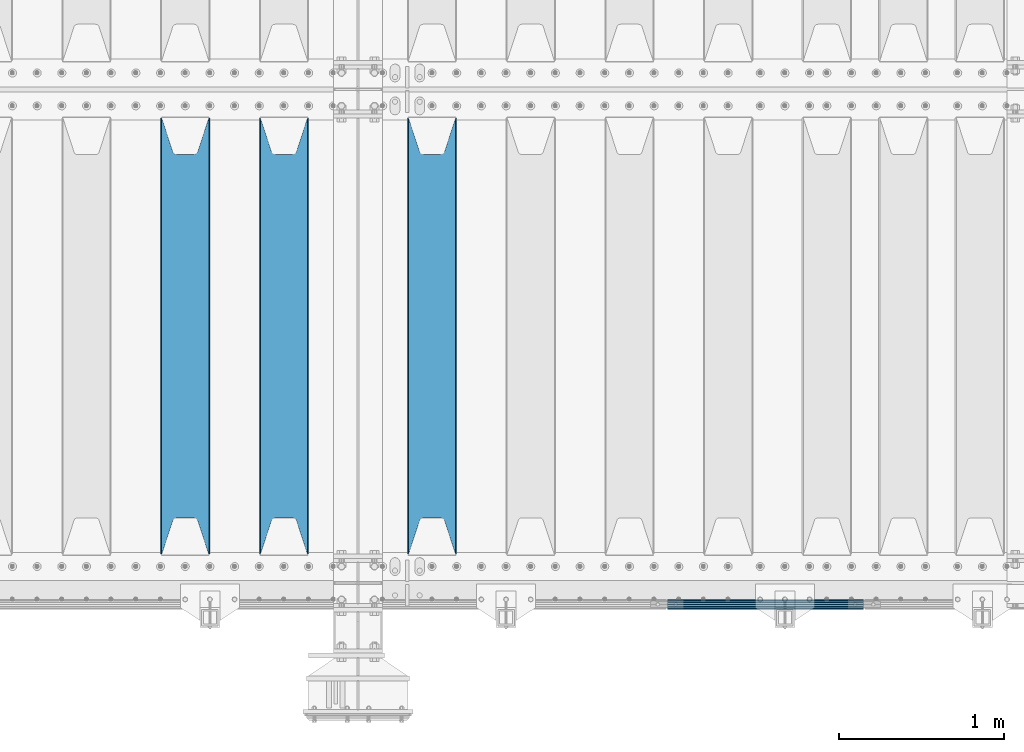
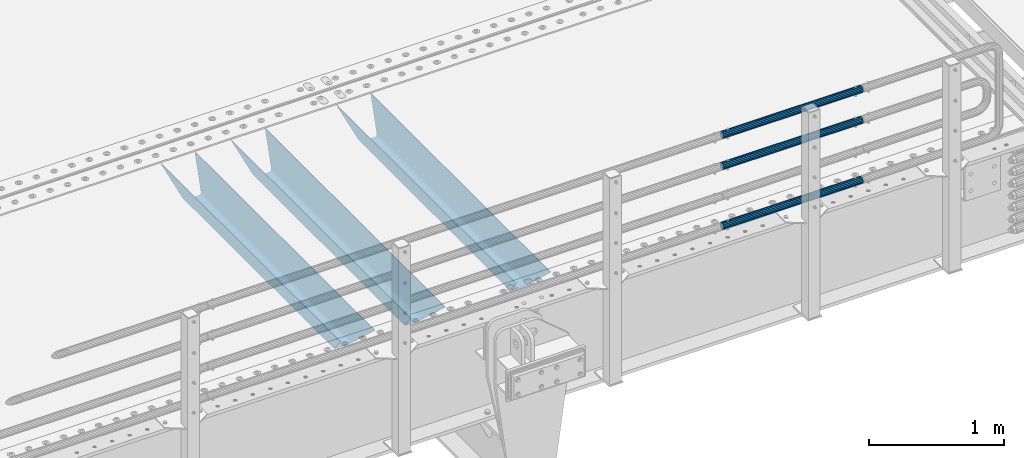
# One storey, part 115 of 247: 6 beams.
"""IFC2X3 building model written with IfcOpenShell, lengths in millimetres."""

from ifc_helpers import new_model, si_unit, frame, origin_with_axes, place, context, subcontext, project, spatial, faceted_brep, material, type_object, element, save


model = new_model("IFC2X3")

# Units and contexts
model_context = context("Model", 3, precision=1e-05, world=origin_with_axes())
body_context = subcontext(model_context, "Body", "Model", "MODEL_VIEW")
ifc_project = project(units=[si_unit("LENGTHUNIT", "METRE", prefix="MILLI"), si_unit("AREAUNIT", "SQUARE_METRE"), si_unit("VOLUMEUNIT", "CUBIC_METRE"), si_unit("MASSUNIT", "GRAM", prefix="KILO"), si_unit("TIMEUNIT", "SECOND"), si_unit("PLANEANGLEUNIT", "RADIAN"), si_unit("SOLIDANGLEUNIT", "STERADIAN"), si_unit("THERMODYNAMICTEMPERATUREUNIT", "DEGREE_CELSIUS"), si_unit("LUMINOUSINTENSITYUNIT", "LUMEN")], contexts=[model_context])

# Site, building, storey
site_placement = place(None, origin_with_axes())
site = spatial("IfcSite", under=ifc_project, at=site_placement, CompositionType="ELEMENT")
building_placement = place(site_placement, origin_with_axes())
building = spatial("IfcBuilding", under=site, at=building_placement, Name="Standard", CompositionType="ELEMENT")
storey_placement = place(building_placement, origin_with_axes())
storey = spatial("IfcBuildingStorey", under=building, at=storey_placement, Name="Undefined", CompositionType="ELEMENT", Elevation=0.0)

# Beams
ifc_material_1 = material(Name="STEEL/S355N")
beam_type_1 = type_object("IfcBeamType", PredefinedType="NOTDEFINED")
beam_1_placement = place(storey_placement, frame((12700.0, 175.0, -115.0), z_axis=(0.0, 0.0, 1.0), x_axis=(0.0, 1.0, 0.0)))
element("IfcBeam", 1, at=beam_1_placement, inside=storey, type_object=beam_type_1, material=ifc_material_1, context=body_context, shape_type="Brep", body=[
    faceted_brep([(0.0, 150.0, 115.0), (0.0, 143.689999999999, 115.0), (2650.00000000297, 143.689999999999, 115.0), (2650.00000000297, 150.0, 115.0), (2650.00000000297, 142.059565218402, 110.0000000031), (2650.00000000297, 148.369565218403, 110.0000000031), (2441.90079219208, -80.1103600731112, -98.0992078077845), (2437.7588105432, -77.5672621345584, -102.241189456673), (2434.06523489746, -74.4080125315522, -105.934765102404), (2430.91086095089, -70.710272125576, -109.089139048974), (2428.37322971128, -66.5649389910068, -111.626770288588), (2426.51472138054, -62.0739139532889, -113.485278619323), (2425.38102192091, -57.3475956567672, -114.618978078955), (2424.99999999987, -52.5021667386536, -115.0), (2424.99999999987, 52.5021667386536, -115.0), (2425.38102192091, 57.3475956567672, -114.618978078955), (2426.51472138054, 62.0739139532889, -113.485278619323), (2428.37322971128, 66.5649389910068, -111.626770288588), (2430.91086095089, 70.710272125576, -109.089139048974), (2434.06523489746, 74.4080125315522, -105.934765102404), (2437.7588105432, 77.5672621345584, -102.241189456673), (2441.90079219208, 80.1103600731112, -98.0992078077846), (2446.38936140511, 81.9747917625791, -93.6106385947584), (2448.24948500409, 76.2713538057251, -91.7505149957729), (2444.62967112262, 74.76777986261, -95.3703288772456), (2441.28936334126, 72.7168944282894, -98.710636658607), (2438.31067330438, 70.1691124903846, -101.689326695487), (2435.76682334747, 67.1870637758839, -104.233176652398), (2433.72034654133, 63.8440531834895, -106.279653458539), (2432.22154950041, 60.222258798236, -107.778450499454), (2431.30727574265, 56.4107117849089, -108.692724257221), (2430.99999999987, 52.5031078186876, -109.0), (2430.99999999987, -52.5031078186876, -109.0), (2431.30727574265, -56.4107117849089, -108.692724257221), (2432.22154950041, -60.222258798236, -107.778450499454), (2433.72034654133, -63.8440531834895, -106.279653458539), (2435.76682334747, -67.1870637758839, -104.233176652398), (2438.31067330438, -70.1691124903846, -101.689326695487), (2441.28936334126, -72.7168944282894, -98.7106366586071), (2444.62967112262, -74.76777986261, -95.3703288772457), (2448.24948500409, -76.2713538057251, -91.7505149957729), (2650.00000000297, -142.059565218402, 110.0000000031), (2650.00000000297, -148.369565218403, 110.0000000031), (2446.38936140511, -81.9747917625791, -93.6106385947584), (2650.00000000297, -143.689999999999, 115.0), (2650.00000000297, -150.0, 115.0), (0.0, -143.689999999999, 115.0), (0.0, -150.0, 115.0), (0.0, -148.369565218261, 110.000000002663), (203.610638597422, -81.9747917625791, -93.6106385947584), (208.099207810448, -80.1103600731112, -98.0992078077845), (212.241189459336, -77.5672621345584, -102.241189456673), (215.934765105068, -74.4080125315522, -105.934765102404), (219.089139051637, -70.710272125576, -109.089139048974), (221.626770291251, -66.5649389910068, -111.626770288588), (223.485278621985, -62.0739139532889, -113.485278619323), (224.618978081617, -57.3475956567672, -114.618978078955), (225.000000002663, -52.5021667386536, -115.0), (225.000000002663, 52.5021667386536, -115.0), (224.618978081617, 57.3475956567672, -114.618978078955), (223.485278621985, 62.0739139532889, -113.485278619323), (221.626770291251, 66.5649389910068, -111.626770288588), (219.089139051637, 70.710272125576, -109.089139048974), (215.934765105068, 74.4080125315522, -105.934765102404), (212.241189459336, 77.5672621345584, -102.241189456673), (208.099207810448, 80.1103600731112, -98.0992078077846), (203.610638597422, 81.9747917625791, -93.6106385947584), (0.0, 148.369565218261, 110.000000002663), (0.0, 142.05956521826, 110.000000002663), (201.750514998436, 76.2713538057251, -91.7505149957729), (205.370328879908, 74.76777986261, -95.3703288772456), (208.710636661271, 72.7168944282894, -98.710636658607), (211.68932669815, 70.1691124903846, -101.689326695487), (214.233176655061, 67.1870637758839, -104.233176652398), (216.279653461202, 63.8440531834895, -106.279653458539), (217.778450502117, 60.222258798236, -107.778450499454), (218.692724259885, 56.4107117849089, -108.692724257221), (219.000000002663, 52.5031078186876, -109.0), (219.000000002663, -52.5031078186876, -109.0), (218.692724259885, -56.4107117849089, -108.692724257221), (217.778450502117, -60.222258798236, -107.778450499454), (216.279653461202, -63.8440531834895, -106.279653458539), (214.233176655061, -67.1870637758839, -104.233176652398), (211.68932669815, -70.1691124903846, -101.689326695487), (208.710636661271, -72.7168944282894, -98.7106366586071), (205.370328879908, -74.76777986261, -95.3703288772457), (201.750514998436, -76.2713538057251, -91.7505149957729), (0.0, -142.05956521826, 110.000000002663)], [[[0, 1, 2, 3]], [[3, 2, 4, 5]], [[6, 7, 8, 9, 10, 11, 12, 13, 14, 15, 16, 17, 18, 19, 20, 21, 22, 5, 4, 23, 24, 25, 26, 27, 28, 29, 30, 31, 32, 33, 34, 35, 36, 37, 38, 39, 40, 41, 42, 43]], [[44, 45, 42, 41]], [[46, 47, 45, 44]], [[43, 42, 45, 47, 48, 49]], [[6, 43, 49, 50]], [[7, 6, 50, 51]], [[8, 7, 51, 52]], [[9, 8, 52, 53]], [[10, 9, 53, 54]], [[11, 10, 54, 55]], [[12, 11, 55, 56]], [[13, 12, 56, 57]], [[14, 13, 57, 58]], [[15, 14, 58, 59]], [[16, 15, 59, 60]], [[17, 16, 60, 61]], [[18, 17, 61, 62]], [[19, 18, 62, 63]], [[20, 19, 63, 64]], [[21, 20, 64, 65]], [[22, 21, 65, 66]], [[0, 3, 5, 22, 66, 67]], [[1, 0, 67, 68]], [[23, 4, 2, 1, 68, 69]], [[24, 23, 69, 70]], [[25, 24, 70, 71]], [[26, 25, 71, 72]], [[27, 26, 72, 73]], [[28, 27, 73, 74]], [[29, 28, 74, 75]], [[30, 29, 75, 76]], [[31, 30, 76, 77]], [[32, 31, 77, 78]], [[33, 32, 78, 79]], [[34, 33, 79, 80]], [[35, 34, 80, 81]], [[36, 35, 81, 82]], [[37, 36, 82, 83]], [[38, 37, 83, 84]], [[39, 38, 84, 85]], [[40, 39, 85, 86]], [[46, 44, 41, 40, 86, 87]], [[47, 46, 87, 48]], [[86, 85, 84, 83, 82, 81, 80, 79, 78, 77, 76, 75, 74, 73, 72, 71, 70, 69, 68, 67, 66, 65, 64, 63, 62, 61, 60, 59, 58, 57, 56, 55, 54, 53, 52, 51, 50, 49, 48, 87]]]),
])
beam_2_placement = place(storey_placement, frame((11800.0, 175.0, -115.0), z_axis=(0.0, 0.0, 1.0), x_axis=(0.0, 1.0, 0.0)))
element("IfcBeam", 2, at=beam_2_placement, inside=storey, type_object=beam_type_1, material=ifc_material_1, context=body_context, shape_type="Brep", body=[
    faceted_brep([(0.0, 150.0, 115.0), (0.0, 143.689999999999, 115.0), (2650.00000000297, 143.689999999999, 115.0), (2650.00000000297, 150.0, 115.0), (2650.00000000297, 142.059565218402, 110.0000000031), (2650.00000000297, 148.369565218403, 110.0000000031), (2441.90079219208, -80.1103600731112, -98.0992078077845), (2437.7588105432, -77.5672621345584, -102.241189456673), (2434.06523489746, -74.4080125315522, -105.934765102404), (2430.91086095089, -70.710272125576, -109.089139048974), (2428.37322971128, -66.5649389910068, -111.626770288588), (2426.51472138054, -62.0739139532889, -113.485278619323), (2425.38102192091, -57.3475956567672, -114.618978078955), (2424.99999999987, -52.5021667386536, -115.0), (2424.99999999987, 52.5021667386536, -115.0), (2425.38102192091, 57.3475956567672, -114.618978078955), (2426.51472138054, 62.0739139532889, -113.485278619323), (2428.37322971128, 66.5649389910068, -111.626770288588), (2430.91086095089, 70.710272125576, -109.089139048974), (2434.06523489746, 74.4080125315522, -105.934765102404), (2437.7588105432, 77.5672621345584, -102.241189456673), (2441.90079219208, 80.1103600731112, -98.0992078077846), (2446.38936140511, 81.9747917625791, -93.6106385947584), (2448.24948500409, 76.2713538057251, -91.7505149957729), (2444.62967112262, 74.76777986261, -95.3703288772456), (2441.28936334126, 72.7168944282894, -98.710636658607), (2438.31067330438, 70.1691124903846, -101.689326695487), (2435.76682334747, 67.1870637758839, -104.233176652398), (2433.72034654133, 63.8440531834895, -106.279653458539), (2432.22154950041, 60.222258798236, -107.778450499454), (2431.30727574265, 56.4107117849089, -108.692724257221), (2430.99999999987, 52.5031078186876, -109.0), (2430.99999999987, -52.5031078186876, -109.0), (2431.30727574265, -56.4107117849089, -108.692724257221), (2432.22154950041, -60.222258798236, -107.778450499454), (2433.72034654133, -63.8440531834895, -106.279653458539), (2435.76682334747, -67.1870637758839, -104.233176652398), (2438.31067330438, -70.1691124903846, -101.689326695487), (2441.28936334126, -72.7168944282894, -98.7106366586071), (2444.62967112262, -74.76777986261, -95.3703288772457), (2448.24948500409, -76.2713538057251, -91.7505149957729), (2650.00000000297, -142.059565218402, 110.0000000031), (2650.00000000297, -148.369565218403, 110.0000000031), (2446.38936140511, -81.9747917625791, -93.6106385947584), (2650.00000000297, -143.689999999999, 115.0), (2650.00000000297, -150.0, 115.0), (0.0, -143.689999999999, 115.0), (0.0, -150.0, 115.0), (0.0, -148.369565218261, 110.000000002663), (203.610638597422, -81.9747917625791, -93.6106385947584), (208.099207810448, -80.1103600731112, -98.0992078077845), (212.241189459336, -77.5672621345584, -102.241189456673), (215.934765105068, -74.4080125315522, -105.934765102404), (219.089139051637, -70.710272125576, -109.089139048974), (221.626770291251, -66.5649389910068, -111.626770288588), (223.485278621985, -62.0739139532889, -113.485278619323), (224.618978081617, -57.3475956567672, -114.618978078955), (225.000000002663, -52.5021667386536, -115.0), (225.000000002663, 52.5021667386536, -115.0), (224.618978081617, 57.3475956567672, -114.618978078955), (223.485278621985, 62.0739139532889, -113.485278619323), (221.626770291251, 66.5649389910068, -111.626770288588), (219.089139051637, 70.710272125576, -109.089139048974), (215.934765105068, 74.4080125315522, -105.934765102404), (212.241189459336, 77.5672621345584, -102.241189456673), (208.099207810448, 80.1103600731112, -98.0992078077846), (203.610638597422, 81.9747917625791, -93.6106385947584), (0.0, 148.369565218261, 110.000000002663), (0.0, 142.05956521826, 110.000000002663), (201.750514998436, 76.2713538057251, -91.7505149957729), (205.370328879908, 74.76777986261, -95.3703288772456), (208.710636661271, 72.7168944282894, -98.710636658607), (211.68932669815, 70.1691124903846, -101.689326695487), (214.233176655061, 67.1870637758839, -104.233176652398), (216.279653461202, 63.8440531834895, -106.279653458539), (217.778450502117, 60.222258798236, -107.778450499454), (218.692724259885, 56.4107117849089, -108.692724257221), (219.000000002663, 52.5031078186876, -109.0), (219.000000002663, -52.5031078186876, -109.0), (218.692724259885, -56.4107117849089, -108.692724257221), (217.778450502117, -60.222258798236, -107.778450499454), (216.279653461202, -63.8440531834895, -106.279653458539), (214.233176655061, -67.1870637758839, -104.233176652398), (211.68932669815, -70.1691124903846, -101.689326695487), (208.710636661271, -72.7168944282894, -98.7106366586071), (205.370328879908, -74.76777986261, -95.3703288772457), (201.750514998436, -76.2713538057251, -91.7505149957729), (0.0, -142.05956521826, 110.000000002663)], [[[0, 1, 2, 3]], [[3, 2, 4, 5]], [[6, 7, 8, 9, 10, 11, 12, 13, 14, 15, 16, 17, 18, 19, 20, 21, 22, 5, 4, 23, 24, 25, 26, 27, 28, 29, 30, 31, 32, 33, 34, 35, 36, 37, 38, 39, 40, 41, 42, 43]], [[44, 45, 42, 41]], [[46, 47, 45, 44]], [[43, 42, 45, 47, 48, 49]], [[6, 43, 49, 50]], [[7, 6, 50, 51]], [[8, 7, 51, 52]], [[9, 8, 52, 53]], [[10, 9, 53, 54]], [[11, 10, 54, 55]], [[12, 11, 55, 56]], [[13, 12, 56, 57]], [[14, 13, 57, 58]], [[15, 14, 58, 59]], [[16, 15, 59, 60]], [[17, 16, 60, 61]], [[18, 17, 61, 62]], [[19, 18, 62, 63]], [[20, 19, 63, 64]], [[21, 20, 64, 65]], [[22, 21, 65, 66]], [[0, 3, 5, 22, 66, 67]], [[1, 0, 67, 68]], [[23, 4, 2, 1, 68, 69]], [[24, 23, 69, 70]], [[25, 24, 70, 71]], [[26, 25, 71, 72]], [[27, 26, 72, 73]], [[28, 27, 73, 74]], [[29, 28, 74, 75]], [[30, 29, 75, 76]], [[31, 30, 76, 77]], [[32, 31, 77, 78]], [[33, 32, 78, 79]], [[34, 33, 79, 80]], [[35, 34, 80, 81]], [[36, 35, 81, 82]], [[37, 36, 82, 83]], [[38, 37, 83, 84]], [[39, 38, 84, 85]], [[40, 39, 85, 86]], [[46, 44, 41, 40, 86, 87]], [[47, 46, 87, 48]], [[86, 85, 84, 83, 82, 81, 80, 79, 78, 77, 76, 75, 74, 73, 72, 71, 70, 69, 68, 67, 66, 65, 64, 63, 62, 61, 60, 59, 58, 57, 56, 55, 54, 53, 52, 51, 50, 49, 48, 87]]]),
])
beam_3_placement = place(storey_placement, frame((11200.0, 175.0, -115.0), z_axis=(0.0, 0.0, 1.0), x_axis=(0.0, 1.0, 0.0)))
element("IfcBeam", 3, at=beam_3_placement, inside=storey, type_object=beam_type_1, material=ifc_material_1, context=body_context, shape_type="Brep", body=[
    faceted_brep([(0.0, 150.0, 115.0), (0.0, 143.689999999999, 115.0), (2650.00000000297, 143.689999999999, 115.0), (2650.00000000297, 150.0, 115.0), (2650.00000000297, 142.059565218402, 110.0000000031), (2650.00000000297, 148.369565218403, 110.0000000031), (2441.90079219208, -80.1103600731112, -98.0992078077845), (2437.7588105432, -77.5672621345584, -102.241189456673), (2434.06523489746, -74.4080125315522, -105.934765102404), (2430.91086095089, -70.710272125576, -109.089139048974), (2428.37322971128, -66.5649389910068, -111.626770288588), (2426.51472138054, -62.0739139532889, -113.485278619323), (2425.38102192091, -57.3475956567672, -114.618978078955), (2424.99999999987, -52.5021667386536, -115.0), (2424.99999999987, 52.5021667386536, -115.0), (2425.38102192091, 57.3475956567672, -114.618978078955), (2426.51472138054, 62.0739139532889, -113.485278619323), (2428.37322971128, 66.5649389910068, -111.626770288588), (2430.91086095089, 70.710272125576, -109.089139048974), (2434.06523489746, 74.4080125315522, -105.934765102404), (2437.7588105432, 77.5672621345584, -102.241189456673), (2441.90079219208, 80.1103600731112, -98.0992078077846), (2446.38936140511, 81.9747917625791, -93.6106385947584), (2448.24948500409, 76.2713538057251, -91.7505149957729), (2444.62967112262, 74.76777986261, -95.3703288772456), (2441.28936334126, 72.7168944282894, -98.710636658607), (2438.31067330438, 70.1691124903846, -101.689326695487), (2435.76682334747, 67.1870637758839, -104.233176652398), (2433.72034654133, 63.8440531834895, -106.279653458539), (2432.22154950041, 60.222258798236, -107.778450499454), (2431.30727574265, 56.4107117849089, -108.692724257221), (2430.99999999987, 52.5031078186876, -109.0), (2430.99999999987, -52.5031078186876, -109.0), (2431.30727574265, -56.4107117849089, -108.692724257221), (2432.22154950041, -60.222258798236, -107.778450499454), (2433.72034654133, -63.8440531834895, -106.279653458539), (2435.76682334747, -67.1870637758839, -104.233176652398), (2438.31067330438, -70.1691124903846, -101.689326695487), (2441.28936334126, -72.7168944282894, -98.7106366586071), (2444.62967112262, -74.76777986261, -95.3703288772457), (2448.24948500409, -76.2713538057251, -91.7505149957729), (2650.00000000297, -142.059565218402, 110.0000000031), (2650.00000000297, -148.369565218403, 110.0000000031), (2446.38936140511, -81.9747917625791, -93.6106385947584), (2650.00000000297, -143.689999999999, 115.0), (2650.00000000297, -150.0, 115.0), (0.0, -143.689999999999, 115.0), (0.0, -150.0, 115.0), (0.0, -148.369565218261, 110.000000002663), (203.610638597422, -81.9747917625791, -93.6106385947584), (208.099207810448, -80.1103600731112, -98.0992078077845), (212.241189459336, -77.5672621345584, -102.241189456673), (215.934765105068, -74.4080125315522, -105.934765102404), (219.089139051637, -70.710272125576, -109.089139048974), (221.626770291251, -66.5649389910068, -111.626770288588), (223.485278621985, -62.0739139532889, -113.485278619323), (224.618978081617, -57.3475956567672, -114.618978078955), (225.000000002663, -52.5021667386536, -115.0), (225.000000002663, 52.5021667386536, -115.0), (224.618978081617, 57.3475956567672, -114.618978078955), (223.485278621985, 62.0739139532889, -113.485278619323), (221.626770291251, 66.5649389910068, -111.626770288588), (219.089139051637, 70.710272125576, -109.089139048974), (215.934765105068, 74.4080125315522, -105.934765102404), (212.241189459336, 77.5672621345584, -102.241189456673), (208.099207810448, 80.1103600731112, -98.0992078077846), (203.610638597422, 81.9747917625791, -93.6106385947584), (0.0, 148.369565218261, 110.000000002663), (0.0, 142.05956521826, 110.000000002663), (201.750514998436, 76.2713538057251, -91.7505149957729), (205.370328879908, 74.76777986261, -95.3703288772456), (208.710636661271, 72.7168944282894, -98.710636658607), (211.68932669815, 70.1691124903846, -101.689326695487), (214.233176655061, 67.1870637758839, -104.233176652398), (216.279653461202, 63.8440531834895, -106.279653458539), (217.778450502117, 60.222258798236, -107.778450499454), (218.692724259885, 56.4107117849089, -108.692724257221), (219.000000002663, 52.5031078186876, -109.0), (219.000000002663, -52.5031078186876, -109.0), (218.692724259885, -56.4107117849089, -108.692724257221), (217.778450502117, -60.222258798236, -107.778450499454), (216.279653461202, -63.8440531834895, -106.279653458539), (214.233176655061, -67.1870637758839, -104.233176652398), (211.68932669815, -70.1691124903846, -101.689326695487), (208.710636661271, -72.7168944282894, -98.7106366586071), (205.370328879908, -74.76777986261, -95.3703288772457), (201.750514998436, -76.2713538057251, -91.7505149957729), (0.0, -142.05956521826, 110.000000002663)], [[[0, 1, 2, 3]], [[3, 2, 4, 5]], [[6, 7, 8, 9, 10, 11, 12, 13, 14, 15, 16, 17, 18, 19, 20, 21, 22, 5, 4, 23, 24, 25, 26, 27, 28, 29, 30, 31, 32, 33, 34, 35, 36, 37, 38, 39, 40, 41, 42, 43]], [[44, 45, 42, 41]], [[46, 47, 45, 44]], [[43, 42, 45, 47, 48, 49]], [[6, 43, 49, 50]], [[7, 6, 50, 51]], [[8, 7, 51, 52]], [[9, 8, 52, 53]], [[10, 9, 53, 54]], [[11, 10, 54, 55]], [[12, 11, 55, 56]], [[13, 12, 56, 57]], [[14, 13, 57, 58]], [[15, 14, 58, 59]], [[16, 15, 59, 60]], [[17, 16, 60, 61]], [[18, 17, 61, 62]], [[19, 18, 62, 63]], [[20, 19, 63, 64]], [[21, 20, 64, 65]], [[22, 21, 65, 66]], [[0, 3, 5, 22, 66, 67]], [[1, 0, 67, 68]], [[23, 4, 2, 1, 68, 69]], [[24, 23, 69, 70]], [[25, 24, 70, 71]], [[26, 25, 71, 72]], [[27, 26, 72, 73]], [[28, 27, 73, 74]], [[29, 28, 74, 75]], [[30, 29, 75, 76]], [[31, 30, 76, 77]], [[32, 31, 77, 78]], [[33, 32, 78, 79]], [[34, 33, 79, 80]], [[35, 34, 80, 81]], [[36, 35, 81, 82]], [[37, 36, 82, 83]], [[38, 37, 83, 84]], [[39, 38, 84, 85]], [[40, 39, 85, 86]], [[46, 44, 41, 40, 86, 87]], [[47, 46, 87, 48]], [[86, 85, 84, 83, 82, 81, 80, 79, 78, 77, 76, 75, 74, 73, 72, 71, 70, 69, 68, 67, 66, 65, 64, 63, 62, 61, 60, 59, 58, 57, 56, 55, 54, 53, 52, 51, 50, 49, 48, 87]]]),
])
ifc_material_2 = material()
beam_type_2 = type_object("IfcBeamType", PredefinedType="NOTDEFINED")
beam_4_placement = place(storey_placement, frame((14132.0000000001, -129.850000000402, 149.549999999726), z_axis=(0.0, -0.999999999999548, -9.5100000000016e-07), x_axis=(1.0, 0.0, 0.0)))
element("IfcBeam", 4, at=beam_4_placement, inside=storey, type_object=beam_type_2, material=ifc_material_2, context=body_context, shape_type="Brep", body=[
    faceted_brep([(0.0, -26.5499999999993, 0.0), (0.0, -24.5290015881747, 10.1602451292931), (1190.0, -24.5290015881747, 10.1602451292929), (1190.0, -26.55, 0.0), (0.0, -18.7736850405036, 18.7736850405028), (1190.0, -18.7736850405028, 18.7736850405036), (0.0, -10.1602451292929, 24.5290015881747), (1190.0, -10.1602451292931, 24.5290015881747), (0.0, 0.0, 26.55), (1190.0, 0.0, 26.5499999999993), (0.0, 10.1602451292929, 24.5290015881747), (1190.0, 10.1602451292932, 24.5290015881747), (0.0, 18.7736850405036, 18.7736850405028), (1190.0, 18.7736850405029, 18.7736850405036), (0.0, 24.5290015881747, 10.1602451292931), (1190.0, 24.5290015881747, 10.1602451292929), (0.0, 26.5499999999993, 0.0), (1190.0, 26.55, 0.0), (0.0, 24.5290015881747, -10.1602451292931), (1190.0, 24.5290015881747, -10.1602451292929), (0.0, 18.7736850405036, -18.7736850405028), (1190.0, 18.7736850405028, -18.7736850405036), (0.0, 10.1602451292929, -24.5290015881747), (1190.0, 10.1602451292931, -24.5290015881747), (0.0, 0.0, -26.55), (1190.0, 0.0, -26.5499999999993), (0.0, -10.1602451292929, -24.5290015881747), (1190.0, -10.1602451292931, -24.5290015881747), (0.0, -18.7736850405036, -18.7736850405028), (1190.0, -18.7736850405028, -18.7736850405036), (0.0, -24.5290015881747, -10.1602451292931), (1190.0, -24.5290015881747, -10.1602451292929), (0.0, -30.1499999999996, 0.0), (0.0, -27.8549679052148, -11.5379054858076), (1190.0, -27.8549679052153, -11.5379054858076), (1190.0, -30.15, 0.0), (0.0, -21.3192694527743, -21.3192694527752), (1190.0, -21.3192694527744, -21.3192694527752), (0.0, -11.5379054858076, -27.8549679052157), (1190.0, -11.5379054858075, -27.8549679052157), (0.0, 0.0, -30.1499999999996), (1190.0, 0.0, -30.1499999999996), (0.0, 11.5379054858076, -27.8549679052157), (1190.0, 11.5379054858075, -27.8549679052157), (0.0, 21.3192694527743, -21.3192694527752), (1190.0, 21.3192694527744, -21.3192694527752), (0.0, 27.8549679052157, -11.5379054858076), (1190.0, 27.8549679052153, -11.5379054858076), (0.0, 30.1499999999996, 0.0), (1190.0, 30.15, 0.0), (0.0, 27.8549679052157, 11.5379054858076), (1190.0, 27.8549679052153, 11.5379054858076), (0.0, 21.3192694527743, 21.3192694527752), (1190.0, 21.3192694527744, 21.3192694527752), (0.0, 11.5379054858076, 27.8549679052157), (1190.0, 11.5379054858075, 27.8549679052157), (0.0, 0.0, 30.1499999999996), (1190.0, 0.0, 30.1499999999996), (0.0, -11.5379054858076, 27.8549679052157), (1190.0, -11.5379054858075, 27.8549679052157), (0.0, -21.3192694527743, 21.3192694527752), (1190.0, -21.3192694527744, 21.3192694527752), (0.0, -27.8549679052157, 11.5379054858076), (1190.0, -27.8549679052153, 11.5379054858076)], [[[0, 1, 2, 3]], [[1, 4, 5, 2]], [[4, 6, 7, 5]], [[6, 8, 9, 7]], [[8, 10, 11, 9]], [[10, 12, 13, 11]], [[12, 14, 15, 13]], [[14, 16, 17, 15]], [[16, 18, 19, 17]], [[18, 20, 21, 19]], [[20, 22, 23, 21]], [[22, 24, 25, 23]], [[24, 26, 27, 25]], [[26, 28, 29, 27]], [[28, 30, 31, 29]], [[30, 0, 3, 31]], [[32, 33, 34, 35]], [[33, 36, 37, 34]], [[36, 38, 39, 37]], [[38, 40, 41, 39]], [[40, 42, 43, 41]], [[42, 44, 45, 43]], [[44, 46, 47, 45]], [[46, 48, 49, 47]], [[48, 50, 51, 49]], [[50, 52, 53, 51]], [[52, 54, 55, 53]], [[54, 56, 57, 55]], [[56, 58, 59, 57]], [[58, 60, 61, 59]], [[60, 62, 63, 61]], [[62, 32, 35, 63]], [[37, 39, 41, 43, 45, 47, 49, 51, 53, 55, 57, 59, 61, 63, 35, 34], [5, 7, 9, 11, 13, 15, 17, 19, 21, 23, 25, 27, 29, 31, 3, 2]], [[62, 60, 58, 56, 54, 52, 50, 48, 46, 44, 42, 40, 38, 36, 33, 32], [30, 28, 26, 24, 22, 20, 18, 16, 14, 12, 10, 8, 6, 4, 1, 0]]]),
])
beam_5_placement = place(storey_placement, frame((14132.0000000001, -129.850000000402, 969.549999999726), z_axis=(0.0, -0.999999999999548, -9.5100000000016e-07), x_axis=(1.0, 0.0, 0.0)))
element("IfcBeam", 5, at=beam_5_placement, inside=storey, type_object=beam_type_2, material=ifc_material_2, context=body_context, shape_type="Brep", body=[
    faceted_brep([(0.0, -26.5499999999993, 0.0), (0.0, -24.5290015881747, 10.1602451292931), (1190.0, -24.5290015881747, 10.1602451292929), (1190.0, -26.55, 0.0), (0.0, -18.7736850405036, 18.7736850405028), (1190.0, -18.7736850405028, 18.7736850405036), (0.0, -10.1602451292929, 24.5290015881747), (1190.0, -10.1602451292931, 24.5290015881747), (0.0, 0.0, 26.55), (1190.0, 0.0, 26.5499999999993), (0.0, 10.1602451292929, 24.5290015881747), (1190.0, 10.1602451292932, 24.5290015881747), (0.0, 18.7736850405036, 18.7736850405028), (1190.0, 18.7736850405029, 18.7736850405036), (0.0, 24.5290015881747, 10.1602451292931), (1190.0, 24.5290015881747, 10.1602451292929), (0.0, 26.5499999999993, 0.0), (1190.0, 26.55, 0.0), (0.0, 24.5290015881747, -10.1602451292931), (1190.0, 24.5290015881747, -10.1602451292929), (0.0, 18.7736850405036, -18.7736850405028), (1190.0, 18.7736850405028, -18.7736850405036), (0.0, 10.1602451292929, -24.5290015881747), (1190.0, 10.1602451292931, -24.5290015881747), (0.0, 0.0, -26.55), (1190.0, 0.0, -26.5499999999993), (0.0, -10.1602451292929, -24.5290015881747), (1190.0, -10.1602451292931, -24.5290015881747), (0.0, -18.7736850405036, -18.7736850405028), (1190.0, -18.7736850405028, -18.7736850405036), (0.0, -24.5290015881747, -10.1602451292931), (1190.0, -24.5290015881747, -10.1602451292929), (0.0, -30.1499999999996, 0.0), (0.0, -27.8549679052148, -11.5379054858076), (1190.0, -27.8549679052153, -11.5379054858076), (1190.0, -30.15, 0.0), (0.0, -21.3192694527743, -21.3192694527752), (1190.0, -21.3192694527744, -21.3192694527752), (0.0, -11.5379054858076, -27.8549679052157), (1190.0, -11.5379054858075, -27.8549679052157), (0.0, 0.0, -30.1499999999996), (1190.0, 0.0, -30.1499999999996), (0.0, 11.5379054858076, -27.8549679052157), (1190.0, 11.5379054858075, -27.8549679052157), (0.0, 21.3192694527743, -21.3192694527752), (1190.0, 21.3192694527744, -21.3192694527752), (0.0, 27.8549679052157, -11.5379054858076), (1190.0, 27.8549679052153, -11.5379054858076), (0.0, 30.1499999999996, 0.0), (1190.0, 30.15, 0.0), (0.0, 27.8549679052157, 11.5379054858076), (1190.0, 27.8549679052153, 11.5379054858076), (0.0, 21.3192694527743, 21.3192694527752), (1190.0, 21.3192694527744, 21.3192694527752), (0.0, 11.5379054858076, 27.8549679052157), (1190.0, 11.5379054858075, 27.8549679052157), (0.0, 0.0, 30.1499999999996), (1190.0, 0.0, 30.1499999999996), (0.0, -11.5379054858076, 27.8549679052157), (1190.0, -11.5379054858075, 27.8549679052157), (0.0, -21.3192694527743, 21.3192694527752), (1190.0, -21.3192694527744, 21.3192694527752), (0.0, -27.8549679052157, 11.5379054858076), (1190.0, -27.8549679052153, 11.5379054858076)], [[[0, 1, 2, 3]], [[1, 4, 5, 2]], [[4, 6, 7, 5]], [[6, 8, 9, 7]], [[8, 10, 11, 9]], [[10, 12, 13, 11]], [[12, 14, 15, 13]], [[14, 16, 17, 15]], [[16, 18, 19, 17]], [[18, 20, 21, 19]], [[20, 22, 23, 21]], [[22, 24, 25, 23]], [[24, 26, 27, 25]], [[26, 28, 29, 27]], [[28, 30, 31, 29]], [[30, 0, 3, 31]], [[32, 33, 34, 35]], [[33, 36, 37, 34]], [[36, 38, 39, 37]], [[38, 40, 41, 39]], [[40, 42, 43, 41]], [[42, 44, 45, 43]], [[44, 46, 47, 45]], [[46, 48, 49, 47]], [[48, 50, 51, 49]], [[50, 52, 53, 51]], [[52, 54, 55, 53]], [[54, 56, 57, 55]], [[56, 58, 59, 57]], [[58, 60, 61, 59]], [[60, 62, 63, 61]], [[62, 32, 35, 63]], [[37, 39, 41, 43, 45, 47, 49, 51, 53, 55, 57, 59, 61, 63, 35, 34], [5, 7, 9, 11, 13, 15, 17, 19, 21, 23, 25, 27, 29, 31, 3, 2]], [[62, 60, 58, 56, 54, 52, 50, 48, 46, 44, 42, 40, 38, 36, 33, 32], [30, 28, 26, 24, 22, 20, 18, 16, 14, 12, 10, 8, 6, 4, 1, 0]]]),
])
beam_6_placement = place(storey_placement, frame((14132.0000000001, -129.850000000402, 689.549999999726), z_axis=(0.0, -0.999999999999548, -9.5100000000016e-07), x_axis=(1.0, 0.0, 0.0)))
element("IfcBeam", 6, at=beam_6_placement, inside=storey, type_object=beam_type_2, material=ifc_material_2, context=body_context, shape_type="Brep", body=[
    faceted_brep([(0.0, -26.5499999999993, 0.0), (0.0, -24.5290015881747, 10.1602451292931), (1190.0, -24.5290015881747, 10.1602451292929), (1190.0, -26.55, 0.0), (0.0, -18.7736850405036, 18.7736850405028), (1190.0, -18.7736850405028, 18.7736850405036), (0.0, -10.1602451292929, 24.5290015881747), (1190.0, -10.1602451292931, 24.5290015881747), (0.0, 0.0, 26.55), (1190.0, 0.0, 26.5499999999993), (0.0, 10.1602451292929, 24.5290015881747), (1190.0, 10.1602451292932, 24.5290015881747), (0.0, 18.7736850405036, 18.7736850405028), (1190.0, 18.7736850405029, 18.7736850405036), (0.0, 24.5290015881747, 10.1602451292931), (1190.0, 24.5290015881747, 10.1602451292929), (0.0, 26.5499999999993, 0.0), (1190.0, 26.55, 0.0), (0.0, 24.5290015881747, -10.1602451292931), (1190.0, 24.5290015881747, -10.1602451292929), (0.0, 18.7736850405036, -18.7736850405028), (1190.0, 18.7736850405028, -18.7736850405036), (0.0, 10.1602451292929, -24.5290015881747), (1190.0, 10.1602451292931, -24.5290015881747), (0.0, 0.0, -26.55), (1190.0, 0.0, -26.5499999999993), (0.0, -10.1602451292929, -24.5290015881747), (1190.0, -10.1602451292931, -24.5290015881747), (0.0, -18.7736850405036, -18.7736850405028), (1190.0, -18.7736850405028, -18.7736850405036), (0.0, -24.5290015881747, -10.1602451292931), (1190.0, -24.5290015881747, -10.1602451292929), (0.0, -30.1499999999996, 0.0), (0.0, -27.8549679052148, -11.5379054858076), (1190.0, -27.8549679052153, -11.5379054858076), (1190.0, -30.15, 0.0), (0.0, -21.3192694527743, -21.3192694527752), (1190.0, -21.3192694527744, -21.3192694527752), (0.0, -11.5379054858076, -27.8549679052157), (1190.0, -11.5379054858075, -27.8549679052157), (0.0, 0.0, -30.1499999999996), (1190.0, 0.0, -30.1499999999996), (0.0, 11.5379054858076, -27.8549679052157), (1190.0, 11.5379054858075, -27.8549679052157), (0.0, 21.3192694527743, -21.3192694527752), (1190.0, 21.3192694527744, -21.3192694527752), (0.0, 27.8549679052157, -11.5379054858076), (1190.0, 27.8549679052153, -11.5379054858076), (0.0, 30.1499999999996, 0.0), (1190.0, 30.15, 0.0), (0.0, 27.8549679052157, 11.5379054858076), (1190.0, 27.8549679052153, 11.5379054858076), (0.0, 21.3192694527743, 21.3192694527752), (1190.0, 21.3192694527744, 21.3192694527752), (0.0, 11.5379054858076, 27.8549679052157), (1190.0, 11.5379054858075, 27.8549679052157), (0.0, 0.0, 30.1499999999996), (1190.0, 0.0, 30.1499999999996), (0.0, -11.5379054858076, 27.8549679052157), (1190.0, -11.5379054858075, 27.8549679052157), (0.0, -21.3192694527743, 21.3192694527752), (1190.0, -21.3192694527744, 21.3192694527752), (0.0, -27.8549679052157, 11.5379054858076), (1190.0, -27.8549679052153, 11.5379054858076)], [[[0, 1, 2, 3]], [[1, 4, 5, 2]], [[4, 6, 7, 5]], [[6, 8, 9, 7]], [[8, 10, 11, 9]], [[10, 12, 13, 11]], [[12, 14, 15, 13]], [[14, 16, 17, 15]], [[16, 18, 19, 17]], [[18, 20, 21, 19]], [[20, 22, 23, 21]], [[22, 24, 25, 23]], [[24, 26, 27, 25]], [[26, 28, 29, 27]], [[28, 30, 31, 29]], [[30, 0, 3, 31]], [[32, 33, 34, 35]], [[33, 36, 37, 34]], [[36, 38, 39, 37]], [[38, 40, 41, 39]], [[40, 42, 43, 41]], [[42, 44, 45, 43]], [[44, 46, 47, 45]], [[46, 48, 49, 47]], [[48, 50, 51, 49]], [[50, 52, 53, 51]], [[52, 54, 55, 53]], [[54, 56, 57, 55]], [[56, 58, 59, 57]], [[58, 60, 61, 59]], [[60, 62, 63, 61]], [[62, 32, 35, 63]], [[37, 39, 41, 43, 45, 47, 49, 51, 53, 55, 57, 59, 61, 63, 35, 34], [5, 7, 9, 11, 13, 15, 17, 19, 21, 23, 25, 27, 29, 31, 3, 2]], [[62, 60, 58, 56, 54, 52, 50, 48, 46, 44, 42, 40, 38, 36, 33, 32], [30, 28, 26, 24, 22, 20, 18, 16, 14, 12, 10, 8, 6, 4, 1, 0]]]),
])

save(model, "model.ifc")
